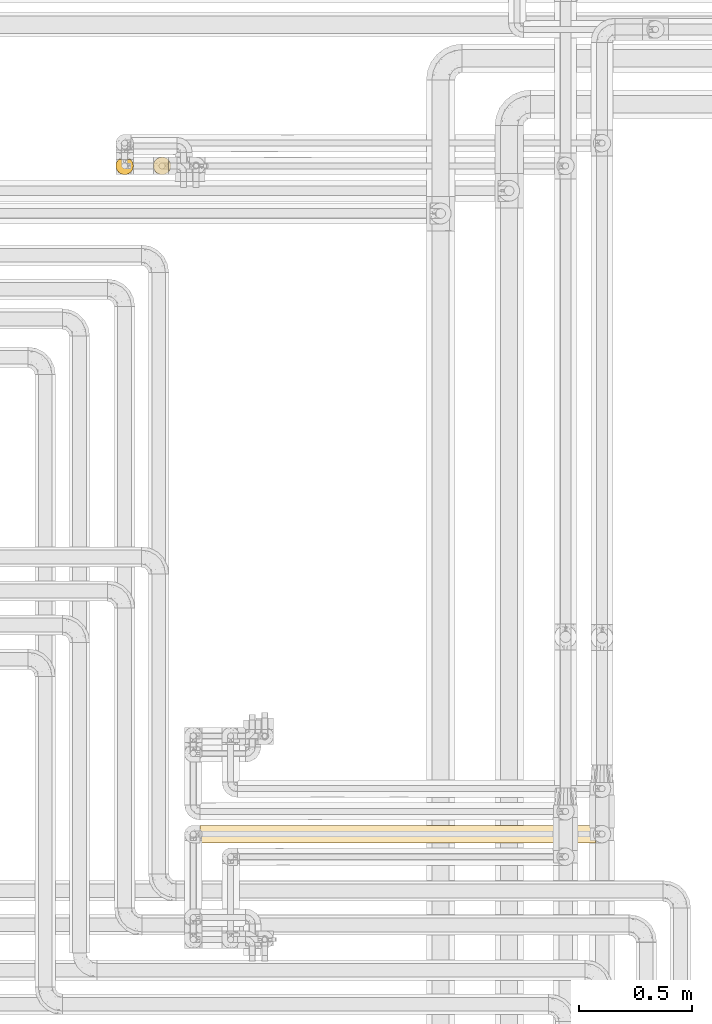
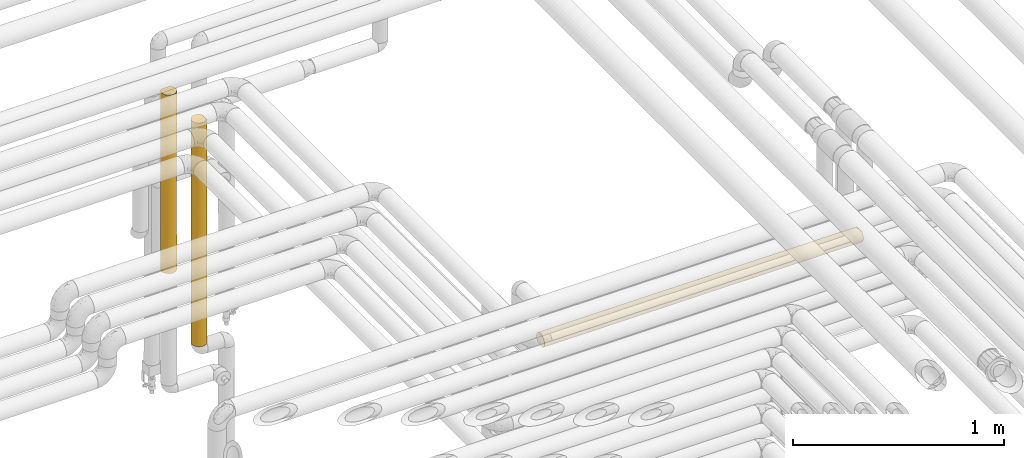
# One storey, part 41 of 827: 3 coverings.
"""IFC2X3 building model written with IfcOpenShell, lengths in millimetres."""

from ifc_helpers import new_model, entity, si_unit, converted_unit, derived_unit, direction, frame, origin, place, context, subcontext, project, spatial, faceted_brep, element, save


model = new_model("IFC2X3")

# Units and contexts
model_context = context("Model", 3, precision=0.01, world=origin(), true_north=direction((6.12303176911189e-17, 1.0)))
body_context = subcontext(model_context, "Body", "Model", "MODEL_VIEW")
ifc_project = project(units=[si_unit("LENGTHUNIT", "METRE", prefix="MILLI"), si_unit("AREAUNIT", "SQUARE_METRE"), si_unit("VOLUMEUNIT", "CUBIC_METRE"), converted_unit("PLANEANGLEUNIT", "DEGREE", entity("IfcRatioMeasure", 0.0174532925199433), si_unit("PLANEANGLEUNIT", "RADIAN"), dimensions=[0, 0, 0, 0, 0, 0, 0]), si_unit("MASSUNIT", "GRAM", prefix="KILO"), derived_unit("MASSDENSITYUNIT", [(si_unit("MASSUNIT", "GRAM", prefix="KILO"), 1), (si_unit("LENGTHUNIT", "METRE"), -3)]), derived_unit("MOMENTOFINERTIAUNIT", [(si_unit("LENGTHUNIT", "METRE"), 4)]), si_unit("TIMEUNIT", "SECOND"), si_unit("FREQUENCYUNIT", "HERTZ"), si_unit("THERMODYNAMICTEMPERATUREUNIT", "DEGREE_CELSIUS"), derived_unit("THERMALTRANSMITTANCEUNIT", [(si_unit("MASSUNIT", "GRAM", prefix="KILO"), 1), (si_unit("THERMODYNAMICTEMPERATUREUNIT", "KELVIN"), -1), (si_unit("TIMEUNIT", "SECOND"), -3)]), derived_unit("VOLUMETRICFLOWRATEUNIT", [(si_unit("LENGTHUNIT", "METRE"), 3), (si_unit("TIMEUNIT", "SECOND"), -1)]), derived_unit("MASSFLOWRATEUNIT", [(si_unit("MASSUNIT", "GRAM", prefix="KILO"), 1), (si_unit("TIMEUNIT", "SECOND"), -1)]), derived_unit("ROTATIONALFREQUENCYUNIT", [(si_unit("TIMEUNIT", "SECOND"), -1)]), si_unit("ELECTRICCURRENTUNIT", "AMPERE"), si_unit("ELECTRICVOLTAGEUNIT", "VOLT"), si_unit("POWERUNIT", "WATT"), si_unit("FORCEUNIT", "NEWTON", prefix="KILO"), si_unit("ILLUMINANCEUNIT", "LUX"), si_unit("LUMINOUSFLUXUNIT", "LUMEN"), si_unit("LUMINOUSINTENSITYUNIT", "CANDELA"), derived_unit("USERDEFINED", [(si_unit("MASSUNIT", "GRAM", prefix="KILO"), -1), (si_unit("LENGTHUNIT", "METRE"), -2), (si_unit("TIMEUNIT", "SECOND"), 3), (si_unit("LUMINOUSFLUXUNIT", "LUMEN"), 1)]), derived_unit("LINEARVELOCITYUNIT", [(si_unit("LENGTHUNIT", "METRE"), 1), (si_unit("TIMEUNIT", "SECOND"), -1)]), si_unit("PRESSUREUNIT", "PASCAL"), derived_unit("USERDEFINED", [(si_unit("LENGTHUNIT", "METRE"), -2), (si_unit("MASSUNIT", "GRAM", prefix="KILO"), 1), (si_unit("TIMEUNIT", "SECOND"), -2)]), derived_unit("LINEARFORCEUNIT", [(si_unit("MASSUNIT", "GRAM", prefix="KILO"), 1), (si_unit("LENGTHUNIT", "METRE"), 1), (si_unit("TIMEUNIT", "SECOND"), -2), (si_unit("LENGTHUNIT", "METRE"), -1)]), derived_unit("PLANARFORCEUNIT", [(si_unit("MASSUNIT", "GRAM", prefix="KILO"), 1), (si_unit("LENGTHUNIT", "METRE"), 1), (si_unit("TIMEUNIT", "SECOND"), -2), (si_unit("LENGTHUNIT", "METRE"), -2)])], contexts=[model_context])

# Site, building, storey
site_placement = place(None, origin())
site = spatial("IfcSite", under=ifc_project, at=site_placement, CompositionType="ELEMENT")
building_placement = place(site_placement, origin())
building = spatial("IfcBuilding", under=site, at=building_placement, CompositionType="ELEMENT")
storey_placement = place(building_placement, frame((0.0, 0.0, 28200.0)))
storey = spatial("IfcBuildingStorey", under=building, at=storey_placement, Name="08", CompositionType="ELEMENT", Elevation=28200.0)

# Coverings
covering_1_placement = place(storey_placement, frame((34650.43, 18294.92, 1257.5)))
element("IfcCovering", 1, at=covering_1_placement, inside=storey, Name=":ADSK_", ObjectType=":ADSK_", PredefinedType="INSULATION", context=body_context, shape_type="Brep", body=[
    faceted_brep([(6.74, 20.8, 1.6), (2.9, 30.06, 1.6), (1.6, 40.0, 1.6), (2.9, 49.93, 1.6), (6.74, 59.2, 1.6), (12.84, 67.15, 1.6), (20.8, 73.25, 1.6), (30.06, 77.09, 1.6), (40.0, 78.4, 1.6), (48.2, 77.51, 1.6), (56.01, 74.9, 1.6), (63.08, 70.68, 1.6), (69.1, 65.05, 1.6), (69.1, 14.94, 1.6), (63.08, 9.31, 1.6), (56.01, 5.09, 1.6), (48.2, 2.48, 1.6), (40.0, 1.6, 1.6), (30.06, 2.9, 1.6), (20.8, 6.74, 1.6), (12.84, 12.84, 1.6), (48.16, 2.47, 1293.5), (55.94, 5.06, 1293.5), (62.99, 9.24, 1293.5), (69.0, 14.82, 1293.5), (69.0, 65.17, 1293.5), (62.99, 70.75, 1293.5), (55.94, 74.93, 1293.5), (48.16, 77.52, 1293.5), (40.0, 78.4, 1293.5), (30.06, 77.09, 1293.5), (20.8, 73.25, 1293.5), (12.84, 67.15, 1293.5), (6.74, 59.2, 1293.5), (2.9, 49.93, 1293.5), (1.6, 40.0, 1293.5), (2.9, 30.06, 1293.5), (6.74, 20.8, 1293.5), (12.84, 12.84, 1293.5), (20.8, 6.74, 1293.5), (30.06, 2.9, 1293.5), (40.0, 1.6, 1293.5), (77.78, 33.17, 1284.71), (75.97, 26.56, 1286.52), (77.48, 31.68, 972.05), (59.58, 6.96, 1107.11), (66.14, 11.87, 1038.3), (52.17, 3.58, 277.97), (40.0, 1.6, 217.97), (66.24, 11.96, 277.98), (59.66, 7.01, 216.52), (73.01, 20.38, 1289.48), (74.55, 23.24, 942.55), (70.47, 16.64, 908.31), (78.4, 40.0, 1067.72), (78.4, 40.0, 876.39), (52.12, 3.56, 1038.32), (59.58, 6.96, 886.32), (76.54, 28.2, 648.87), (74.59, 23.33, 353.75), (77.52, 31.84, 335.45), (78.4, 40.0, 227.27), (78.4, 40.0, 443.64), (71.31, 17.78, 216.97), (73.07, 20.48, 5.57), (66.0, 11.74, 786.74), (65.83, 11.58, 548.84), (70.86, 17.15, 647.83), (76.0, 26.63, 8.5), (77.79, 33.21, 10.29), (71.01, 17.35, 432.2), (40.0, 1.6, 428.0), (52.92, 3.84, 494.01), (60.93, 7.8, 674.6), (59.66, 7.01, 462.3), (50.4, 3.03, 697.42), (40.0, 1.6, 1077.12), (78.4, 40.0, 1284.1), (78.4, 40.0, 10.9), (78.4, 40.0, 660.01), (40.0, 1.6, 860.75), (40.0, 1.6, 650.71), (40.0, 1.6, 644.38), (40.0, 1.6, 434.34), (40.0, 1.6, 867.09), (16.62, 9.53, 1034.3), (9.53, 16.62, 969.22), (32.88, 2.26, 326.15), (31.56, 2.53, 650.71), (25.3, 4.52, 373.29), (25.3, 4.52, 921.8), (32.84, 2.27, 972.1), (1.6, 40.0, 1077.12), (1.6, 40.0, 217.97), (23.7, 5.22, 684.79), (1.6, 40.0, 428.0), (2.27, 32.83, 322.99), (4.52, 25.3, 1048.44), (6.84, 20.62, 572.76), (11.32, 14.46, 577.99), (7.88, 18.94, 777.8), (2.29, 32.71, 968.94), (4.52, 25.3, 763.78), (9.53, 16.62, 373.29), (4.52, 25.3, 272.12), (16.62, 9.53, 272.12), (16.62, 9.53, 647.55), (3.48, 28.11, 517.95), (2.22, 33.12, 731.85), (12.38, 13.31, 791.26), (17.3, 9.02, 840.92), (1.6, 40.0, 867.09), (1.6, 40.0, 860.75), (1.6, 40.0, 644.38), (1.6, 40.0, 434.34), (1.6, 40.0, 650.71), (9.53, 63.37, 1034.3), (16.62, 70.46, 969.22), (2.26, 47.12, 326.15), (2.53, 48.43, 650.71), (4.52, 54.69, 373.29), (4.52, 54.69, 921.8), (2.27, 47.15, 972.1), (40.0, 78.4, 1077.12), (40.0, 78.4, 217.97), (40.0, 78.4, 214.8), (5.22, 56.29, 684.79), (40.0, 78.4, 428.0), (32.83, 77.72, 322.99), (25.3, 75.47, 1048.44), (20.62, 73.15, 572.76), (14.46, 68.67, 577.99), (18.94, 72.11, 777.8), (32.71, 77.7, 968.94), (25.3, 75.47, 763.78), (16.62, 70.46, 373.29), (25.3, 75.47, 272.12), (9.53, 63.37, 272.12), (9.53, 63.37, 647.55), (28.11, 76.51, 517.95), (33.12, 77.77, 731.85), (13.31, 67.61, 791.26), (9.02, 62.69, 840.92), (40.0, 78.4, 860.75), (40.0, 78.4, 644.37), (52.12, 76.43, 1015.67), (74.55, 56.75, 943.52), (70.97, 62.69, 863.0), (71.23, 62.33, 1078.4), (59.58, 73.03, 828.13), (59.58, 73.03, 1078.96), (65.9, 68.35, 749.13), (66.06, 68.19, 508.81), (60.97, 72.16, 617.52), (73.01, 59.61, 1289.48), (59.66, 72.98, 186.49), (66.24, 68.03, 256.35), (66.14, 68.12, 1015.66), (76.0, 53.36, 8.5), (73.07, 59.51, 5.57), (74.59, 56.66, 352.23), (52.17, 76.41, 256.35), (75.97, 53.43, 1286.52), (77.78, 46.82, 1284.71), (77.48, 48.31, 972.05), (59.66, 72.98, 406.31), (50.42, 76.95, 603.65), (70.53, 63.27, 387.8), (47.86, 77.58, 822.29), (70.94, 62.73, 647.24), (77.79, 46.78, 10.29), (77.52, 48.15, 335.45), (76.52, 51.85, 648.58)], [[[0, 1, 2, 3, 4, 5, 6, 7, 8, 9, 10, 11, 12, 13, 14, 15, 16, 17, 18, 19, 20]], [[21, 22, 23, 24, 25, 26, 27, 28, 29, 30, 31, 32, 33, 34, 35, 36, 37, 38, 39, 40, 41]], [[42, 43, 44]], [[45, 46, 23]], [[46, 24, 23]], [[47, 48, 16]], [[14, 49, 50]], [[43, 51, 52]], [[53, 24, 46]], [[54, 44, 55]], [[45, 56, 57]], [[58, 59, 60]], [[61, 62, 60]], [[63, 64, 59]], [[65, 66, 67]], [[15, 47, 16]], [[68, 59, 64]], [[46, 65, 53]], [[61, 60, 69]], [[59, 70, 63]], [[71, 47, 72]], [[66, 65, 73]], [[63, 13, 64]], [[50, 15, 14]], [[74, 47, 50]], [[45, 23, 22]], [[56, 75, 57]], [[21, 76, 56]], [[54, 77, 42]], [[58, 67, 59]], [[49, 14, 13]], [[52, 67, 58]], [[22, 21, 56]], [[72, 47, 74]], [[16, 48, 17]], [[68, 69, 60]], [[69, 78, 61]], [[58, 60, 62]], [[60, 59, 68]], [[79, 55, 58, 62]], [[55, 44, 58]], [[75, 80, 81, 82, 83, 71]], [[75, 56, 80]], [[75, 72, 73]], [[65, 46, 57]], [[53, 51, 24]], [[44, 43, 52]], [[42, 44, 54]], [[58, 44, 52]], [[56, 45, 22]], [[71, 48, 47]], [[46, 45, 57]], [[73, 65, 57]], [[53, 67, 52]], [[74, 49, 66]], [[70, 49, 63]], [[67, 53, 65]], [[51, 53, 52]], [[75, 73, 57]], [[66, 73, 74]], [[74, 50, 49]], [[15, 50, 47]], [[70, 59, 67]], [[13, 63, 49]], [[67, 66, 70]], [[49, 70, 66]], [[76, 21, 41]], [[56, 76, 84, 80]], [[73, 72, 74]], [[71, 72, 75]], [[85, 38, 86]], [[87, 88, 89]], [[18, 48, 87]], [[18, 89, 19]], [[40, 39, 90]], [[91, 40, 90]], [[36, 35, 92]], [[1, 93, 2]], [[83, 88, 87]], [[89, 88, 94]], [[95, 93, 96]], [[37, 97, 86]], [[98, 99, 100]], [[97, 101, 102]], [[40, 76, 41]], [[18, 17, 48]], [[87, 48, 71, 83]], [[103, 104, 0]], [[105, 20, 19]], [[37, 36, 97]], [[37, 86, 38]], [[89, 105, 19]], [[103, 0, 20]], [[1, 0, 104]], [[105, 106, 99]], [[102, 107, 98]], [[108, 107, 102]], [[38, 85, 39]], [[102, 101, 108]], [[109, 110, 85]], [[98, 107, 104]], [[106, 105, 89]], [[103, 20, 105]], [[85, 86, 109]], [[90, 39, 85]], [[92, 101, 36]], [[97, 102, 100]], [[101, 92, 111, 112]], [[101, 112, 108]], [[36, 101, 97]], [[107, 113, 114, 95]], [[96, 107, 95]], [[108, 113, 107]], [[98, 104, 103]], [[103, 99, 98]], [[109, 100, 99]], [[108, 112, 115, 113]], [[105, 99, 103]], [[109, 99, 106]], [[109, 106, 110]], [[109, 86, 100]], [[97, 100, 86]], [[98, 100, 102]], [[88, 83, 82, 81, 80, 84]], [[18, 87, 89]], [[91, 88, 84]], [[88, 90, 94]], [[40, 91, 76]], [[84, 76, 91]], [[88, 91, 90]], [[96, 1, 104]], [[1, 96, 93]], [[107, 96, 104]], [[94, 110, 106]], [[90, 85, 110]], [[110, 94, 90]], [[89, 94, 106]], [[116, 32, 117]], [[118, 119, 120]], [[3, 93, 118]], [[3, 120, 4]], [[34, 33, 121]], [[122, 34, 121]], [[30, 29, 123]], [[7, 124, 125, 8]], [[114, 119, 118]], [[120, 119, 126]], [[127, 124, 128]], [[31, 129, 117]], [[130, 131, 132]], [[129, 133, 134]], [[34, 92, 35]], [[3, 2, 93]], [[118, 93, 95, 114]], [[135, 136, 6]], [[137, 5, 4]], [[31, 30, 129]], [[31, 117, 32]], [[120, 137, 4]], [[135, 6, 5]], [[7, 6, 136]], [[137, 138, 131]], [[134, 139, 130]], [[140, 139, 134]], [[32, 116, 33]], [[134, 133, 140]], [[141, 142, 116]], [[130, 139, 136]], [[138, 137, 120]], [[135, 5, 137]], [[116, 117, 141]], [[121, 33, 116]], [[123, 133, 30]], [[129, 134, 132]], [[133, 123, 143]], [[133, 143, 140]], [[30, 133, 129]], [[139, 144, 127]], [[128, 139, 127]], [[140, 144, 139]], [[130, 136, 135]], [[135, 131, 130]], [[141, 132, 131]], [[140, 143, 144]], [[137, 131, 135]], [[141, 131, 138]], [[141, 138, 142]], [[141, 117, 132]], [[129, 132, 117]], [[130, 132, 134]], [[119, 114, 113, 115, 112, 111]], [[3, 118, 120]], [[122, 119, 111]], [[119, 121, 126]], [[34, 122, 92]], [[111, 92, 122]], [[119, 122, 121]], [[128, 7, 136]], [[7, 128, 124]], [[139, 128, 136]], [[126, 142, 138]], [[121, 116, 142]], [[142, 126, 121]], [[120, 126, 138]], [[145, 123, 28]], [[146, 147, 148]], [[149, 145, 150]], [[151, 152, 153]], [[148, 25, 154]], [[11, 155, 156]], [[26, 157, 150]], [[123, 29, 28]], [[158, 159, 160]], [[9, 125, 161]], [[162, 163, 164]], [[27, 145, 28]], [[165, 161, 166]], [[11, 10, 155]], [[156, 152, 167]], [[168, 149, 166]], [[151, 169, 152]], [[150, 27, 26]], [[170, 171, 61]], [[25, 157, 26]], [[171, 160, 172]], [[164, 163, 54]], [[143, 123, 168, 144]], [[165, 155, 161]], [[54, 55, 164]], [[170, 158, 171]], [[167, 12, 156]], [[146, 148, 154]], [[11, 156, 12]], [[172, 169, 146]], [[61, 78, 170]], [[146, 154, 162]], [[10, 9, 161]], [[172, 55, 79, 62]], [[171, 158, 160]], [[62, 61, 171]], [[160, 169, 172]], [[163, 77, 54]], [[172, 62, 171]], [[149, 168, 145]], [[166, 161, 127]], [[166, 127, 144]], [[153, 166, 149]], [[152, 156, 165]], [[167, 159, 12]], [[164, 172, 146]], [[125, 9, 8]], [[164, 146, 162]], [[161, 155, 10]], [[156, 155, 165]], [[153, 152, 165]], [[167, 169, 160]], [[149, 157, 151]], [[147, 157, 148]], [[169, 167, 152]], [[159, 167, 160]], [[166, 153, 165]], [[151, 153, 149]], [[149, 150, 157]], [[27, 150, 145]], [[147, 146, 169]], [[25, 148, 157]], [[169, 151, 147]], [[157, 147, 151]], [[168, 123, 145]], [[55, 172, 164]], [[161, 125, 124, 127]], [[144, 168, 166]], [[12, 159, 158, 170, 78, 69, 68, 64, 13]], [[24, 51, 43, 42, 77, 163, 162, 154, 25]]]),
])
covering_2_placement = place(storey_placement, frame((34855.35, 15349.6, 2960.0)))
element("IfcCovering", 2, at=covering_2_placement, inside=storey, Name=":ADSK_", ObjectType=":ADSK_", PredefinedType="INSULATION", context=body_context, shape_type="Brep", body=[
    faceted_brep([(1745.19, 59.2, 6.74), (1745.19, 67.15, 12.84), (1745.19, 73.25, 20.8), (1745.19, 77.09, 30.06), (1745.19, 78.4, 40.0), (1745.19, 77.51, 48.2), (1745.19, 74.9, 56.01), (1745.19, 70.68, 63.08), (1745.19, 65.05, 69.1), (1745.19, 14.94, 69.1), (1745.19, 9.31, 63.08), (1745.19, 5.09, 56.01), (1745.19, 2.48, 48.2), (1745.19, 1.6, 40.0), (1745.19, 2.9, 30.06), (1745.19, 6.74, 20.8), (1745.19, 12.84, 12.84), (1745.19, 20.8, 6.74), (1745.19, 30.06, 2.9), (1745.19, 40.0, 1.6), (1745.19, 49.93, 2.9), (1.6, 77.09, 49.93), (1.6, 78.4, 40.0), (1.6, 77.51, 31.79), (1.6, 74.9, 23.98), (1.6, 70.68, 16.91), (1.6, 65.05, 10.9), (1.6, 14.94, 10.9), (1.6, 9.31, 16.91), (1.6, 5.09, 23.98), (1.6, 2.48, 31.79), (1.6, 1.6, 40.0), (1.6, 2.9, 49.93), (1.6, 6.74, 59.2), (1.6, 12.84, 67.15), (1.6, 20.8, 73.25), (1.6, 30.06, 77.09), (1.6, 40.0, 78.4), (1.6, 49.93, 77.09), (1.6, 59.2, 73.25), (1.6, 67.15, 67.15), (1.6, 73.25, 59.2), (218.66, 7.01, 20.33), (287.24, 11.96, 13.75), (544.14, 12.26, 13.43), (717.19, 17.22, 9.08), (783.66, 11.23, 14.56), (287.23, 3.58, 27.82), (217.97, 1.6, 40.0), (616.82, 2.85, 30.25), (434.34, 1.6, 40.0), (485.18, 7.01, 20.33), (335.45, 31.75, 2.49), (688.07, 29.53, 3.05), (384.99, 23.31, 5.41), (406.86, 16.78, 9.41), (194.06, 17.51, 8.86), (1248.41, 14.02, 11.72), (1485.61, 16.62, 9.53), (1419.01, 9.53, 16.62), (1528.82, 1.6, 40.0), (1497.5, 4.52, 25.3), (1417.48, 2.29, 32.74), (1210.56, 4.52, 25.3), (806.62, 6.2, 21.76), (967.81, 3.45, 28.2), (227.27, 40.0, 1.6), (10.29, 33.21, 2.2), (1183.1, 33.11, 2.22), (1310.79, 40.0, 1.6), (1419.81, 32.72, 2.29), (1528.82, 40.0, 1.6), (8.5, 26.63, 4.0), (956.23, 28.08, 3.49), (794.35, 23.31, 5.41), (1499.45, 25.3, 4.52), (5.57, 20.48, 6.92), (443.64, 40.0, 1.6), (1220.82, 7.97, 18.8), (1027.44, 6.38, 21.43), (1181.82, 2.22, 33.08), (10.9, 40.0, 1.6), (660.01, 40.0, 1.6), (876.39, 40.0, 1.6), (1026.75, 10.9, 14.94), (1003.5, 19.04, 7.82), (589.67, 22.07, 6.04), (867.09, 1.6, 40.0), (660.17, 1.6, 40.0), (650.71, 1.6, 40.0), (440.64, 1.6, 40.0), (1304.51, 19.53, 7.5), (1312.45, 1.6, 40.0), (1306.14, 1.6, 40.0), (1086.61, 1.6, 40.0), (879.7, 1.6, 40.0), (1096.08, 1.6, 40.0), (1214.19, 25.3, 4.52), (1093.59, 40.0, 1.6), (335.45, 48.24, 2.49), (688.07, 50.46, 3.05), (406.86, 63.21, 9.41), (194.06, 62.48, 8.86), (287.24, 68.03, 13.75), (287.23, 76.41, 27.82), (218.66, 72.98, 20.33), (544.14, 67.73, 13.43), (10.29, 46.78, 2.2), (8.5, 53.36, 4.0), (485.18, 72.98, 20.33), (1181.82, 77.77, 33.08), (1306.14, 78.4, 40.0), (1417.48, 77.7, 32.74), (1312.45, 78.4, 40.0), (1528.82, 78.4, 40.0), (1499.45, 54.69, 4.52), (1419.81, 47.27, 2.29), (1214.19, 54.69, 4.52), (384.99, 56.68, 5.41), (1183.1, 46.89, 2.22), (956.23, 51.91, 3.49), (806.62, 73.79, 21.76), (967.81, 76.54, 28.2), (1027.44, 73.61, 21.43), (1497.5, 75.47, 25.3), (5.57, 59.51, 6.92), (1419.01, 70.46, 16.62), (1485.61, 63.37, 9.53), (1220.82, 72.02, 18.8), (616.82, 77.14, 30.25), (1210.56, 75.47, 25.3), (434.34, 78.4, 40.0), (217.97, 78.4, 40.0), (1003.5, 60.95, 7.82), (717.19, 62.77, 9.08), (794.35, 56.68, 5.41), (589.67, 57.93, 6.04), (1248.41, 65.97, 11.72), (1026.75, 69.09, 14.94), (783.66, 68.76, 14.56), (440.65, 78.4, 40.0), (650.71, 78.4, 40.0), (660.17, 78.4, 40.0), (867.09, 78.4, 40.0), (1304.51, 60.46, 7.5), (1086.61, 78.4, 40.0), (879.7, 78.4, 40.0), (1096.07, 78.4, 40.0), (249.29, 75.47, 54.69), (327.78, 70.46, 63.37), (525.97, 72.02, 61.19), (1411.33, 48.24, 77.5), (1738.29, 53.36, 76.0), (1361.8, 56.68, 74.58), (247.34, 54.69, 75.47), (532.6, 54.69, 75.47), (563.69, 46.89, 77.77), (790.56, 51.91, 76.5), (536.23, 75.47, 54.69), (719.35, 73.61, 58.56), (261.18, 63.37, 70.46), (329.31, 77.7, 47.25), (564.97, 77.77, 46.91), (1459.55, 76.41, 52.17), (940.16, 73.79, 58.23), (778.98, 76.54, 51.79), (1058.72, 50.46, 76.94), (1303.14, 40.0, 78.4), (1202.65, 67.73, 66.56), (1459.55, 68.03, 66.24), (1261.61, 72.98, 59.66), (1528.13, 72.98, 59.66), (1519.52, 40.0, 78.4), (1086.77, 40.0, 78.4), (870.4, 40.0, 78.4), (1736.5, 46.78, 77.79), (1129.97, 77.14, 49.74), (1339.93, 63.21, 70.58), (1552.73, 62.48, 71.13), (1741.22, 59.51, 73.07), (217.97, 40.0, 78.4), (326.98, 47.27, 77.7), (1735.89, 40.0, 78.4), (743.28, 60.95, 72.17), (1029.6, 62.77, 70.91), (952.44, 56.68, 74.58), (1157.12, 57.93, 73.95), (498.37, 65.97, 68.27), (720.04, 69.09, 65.05), (963.13, 68.76, 65.43), (442.27, 60.46, 72.49), (436.0, 40.0, 78.4), (653.2, 40.0, 78.4), (247.34, 25.3, 75.47), (1339.93, 16.78, 70.58), (1029.6, 17.22, 70.91), (1202.65, 12.26, 66.56), (563.69, 33.11, 77.77), (326.98, 32.72, 77.7), (790.56, 28.08, 76.5), (952.44, 23.31, 74.58), (1058.72, 29.53, 76.94), (1552.73, 17.51, 71.13), (1741.22, 20.48, 73.07), (327.78, 9.53, 63.37), (249.29, 4.52, 54.69), (1738.29, 26.63, 76.0), (1361.8, 23.31, 74.58), (1528.13, 7.01, 59.66), (1411.33, 31.75, 77.5), (1736.5, 33.21, 77.79), (1459.55, 11.96, 66.24), (1459.55, 3.58, 52.17), (329.31, 2.29, 47.25), (536.23, 4.52, 54.69), (498.37, 14.02, 68.27), (261.18, 16.62, 70.46), (1261.61, 7.01, 59.66), (963.13, 11.23, 65.43), (1129.97, 2.85, 49.74), (940.16, 6.2, 58.23), (778.98, 3.45, 51.79), (719.35, 6.38, 58.56), (525.97, 7.97, 61.19), (564.97, 2.22, 46.91), (720.04, 10.9, 65.05), (743.28, 19.04, 72.17), (1157.12, 22.07, 73.95), (442.27, 19.53, 72.49), (532.6, 25.3, 75.47)], [[[0, 1, 2, 3, 4, 5, 6, 7, 8, 9, 10, 11, 12, 13, 14, 15, 16, 17, 18, 19, 20]], [[21, 22, 23, 24, 25, 26, 27, 28, 29, 30, 31, 32, 33, 34, 35, 36, 37, 38, 39, 40, 41]], [[42, 29, 28]], [[43, 42, 28]], [[44, 45, 46]], [[47, 48, 30]], [[47, 49, 50]], [[47, 42, 51]], [[52, 53, 54]], [[54, 55, 56]], [[57, 58, 59]], [[14, 13, 60]], [[61, 62, 63]], [[49, 64, 65]], [[27, 43, 28]], [[29, 47, 30]], [[66, 52, 67]], [[14, 61, 15]], [[68, 69, 70]], [[69, 71, 70]], [[43, 44, 51]], [[56, 72, 54]], [[61, 59, 15]], [[73, 74, 53]], [[16, 15, 59]], [[75, 18, 17]], [[58, 16, 59]], [[56, 27, 76]], [[66, 77, 52]], [[55, 45, 44]], [[72, 67, 52]], [[49, 47, 51]], [[59, 78, 57]], [[63, 79, 78]], [[63, 62, 80]], [[16, 58, 17]], [[67, 81, 66]], [[18, 71, 19]], [[53, 77, 82, 83]], [[52, 54, 72]], [[84, 85, 57]], [[53, 74, 86]], [[63, 80, 65]], [[45, 74, 85]], [[49, 51, 64]], [[49, 87, 88, 89, 90, 50]], [[48, 47, 50]], [[48, 31, 30]], [[58, 91, 75]], [[60, 62, 14]], [[61, 63, 78]], [[58, 75, 17]], [[70, 18, 75]], [[51, 44, 46]], [[65, 79, 63]], [[62, 60, 92, 93]], [[62, 93, 80]], [[14, 62, 61]], [[65, 94, 95, 87]], [[65, 64, 79]], [[65, 80, 94]], [[49, 65, 87]], [[80, 93, 96, 94]], [[97, 68, 70]], [[18, 70, 71]], [[97, 70, 75]], [[73, 68, 97]], [[73, 98, 68]], [[73, 97, 85]], [[83, 73, 53]], [[57, 91, 58]], [[46, 85, 84]], [[98, 73, 83]], [[98, 69, 68]], [[91, 85, 97]], [[64, 84, 79]], [[78, 59, 61]], [[79, 84, 78]], [[57, 78, 84]], [[55, 44, 43]], [[85, 46, 45]], [[84, 64, 46]], [[51, 46, 64]], [[43, 27, 56]], [[55, 54, 86]], [[56, 76, 72]], [[43, 56, 55]], [[85, 91, 57]], [[75, 91, 97]], [[85, 74, 73]], [[86, 74, 45]], [[55, 86, 45]], [[53, 86, 54]], [[51, 42, 43]], [[29, 42, 47]], [[77, 53, 52]], [[77, 99, 100]], [[101, 102, 103]], [[104, 105, 24]], [[101, 103, 106]], [[105, 103, 25]], [[26, 25, 103]], [[107, 108, 99]], [[77, 66, 99]], [[106, 103, 109]], [[110, 111, 112]], [[20, 19, 71]], [[112, 111, 113, 114]], [[115, 116, 117]], [[99, 108, 118]], [[115, 0, 20]], [[117, 119, 120]], [[121, 122, 123]], [[82, 77, 100, 83]], [[66, 81, 107]], [[3, 2, 124]], [[104, 24, 23]], [[125, 102, 108]], [[126, 2, 1]], [[127, 126, 1]], [[124, 126, 128]], [[109, 104, 129]], [[121, 109, 129]], [[103, 105, 109]], [[130, 128, 123]], [[131, 104, 132]], [[102, 125, 26]], [[104, 23, 132]], [[129, 104, 131]], [[127, 1, 0]], [[3, 114, 4]], [[117, 120, 133]], [[107, 99, 66]], [[117, 116, 119]], [[99, 118, 100]], [[134, 135, 136]], [[133, 120, 135]], [[126, 127, 137]], [[138, 133, 139]], [[129, 131, 140, 141, 142, 143]], [[110, 130, 122]], [[23, 22, 132]], [[115, 127, 0]], [[133, 137, 144]], [[126, 124, 2]], [[112, 3, 124]], [[71, 116, 20]], [[115, 117, 144]], [[129, 143, 122]], [[139, 134, 106]], [[130, 110, 112]], [[3, 112, 114]], [[130, 112, 124]], [[130, 123, 122]], [[122, 145, 110]], [[129, 122, 121]], [[116, 71, 69]], [[122, 143, 146, 145]], [[110, 145, 147, 111]], [[116, 69, 119]], [[20, 116, 115]], [[120, 98, 83]], [[120, 83, 100]], [[119, 98, 120]], [[135, 120, 100]], [[139, 133, 134]], [[138, 128, 137]], [[119, 69, 98]], [[144, 137, 127]], [[133, 138, 137]], [[130, 124, 128]], [[138, 121, 123]], [[137, 128, 126]], [[138, 123, 128]], [[139, 109, 121]], [[134, 136, 101]], [[109, 139, 106]], [[121, 138, 139]], [[134, 101, 106]], [[118, 108, 102]], [[103, 102, 26]], [[118, 102, 101]], [[115, 144, 127]], [[133, 144, 117]], [[136, 100, 118]], [[133, 135, 134]], [[100, 136, 135]], [[101, 136, 118]], [[24, 105, 25]], [[109, 105, 104]], [[148, 149, 150]], [[151, 152, 153]], [[154, 39, 38]], [[155, 156, 157]], [[158, 150, 159]], [[40, 160, 149]], [[161, 140, 131, 132]], [[162, 140, 161]], [[113, 163, 114]], [[159, 164, 165]], [[151, 166, 167]], [[168, 169, 170]], [[169, 171, 170]], [[167, 172, 151]], [[163, 171, 6]], [[173, 167, 166, 174]], [[149, 41, 40]], [[175, 152, 151]], [[164, 170, 176]], [[177, 178, 169]], [[177, 169, 168]], [[7, 171, 169]], [[41, 148, 21]], [[7, 169, 8]], [[152, 179, 178]], [[38, 37, 180]], [[170, 163, 176]], [[154, 181, 155]], [[172, 182, 175]], [[163, 6, 5]], [[178, 179, 8]], [[163, 5, 114]], [[176, 163, 113]], [[160, 40, 39]], [[21, 132, 22]], [[155, 157, 183]], [[175, 151, 172]], [[155, 181, 156]], [[151, 153, 166]], [[184, 185, 186]], [[183, 157, 185]], [[149, 160, 187]], [[188, 183, 189]], [[176, 113, 111, 147, 145, 146]], [[162, 158, 165]], [[5, 4, 114]], [[154, 160, 39]], [[183, 187, 190]], [[149, 148, 41]], [[161, 21, 148]], [[180, 181, 38]], [[154, 155, 190]], [[176, 146, 165]], [[189, 184, 168]], [[158, 162, 161]], [[21, 161, 132]], [[158, 161, 148]], [[158, 159, 165]], [[165, 142, 162]], [[176, 165, 164]], [[181, 180, 191]], [[165, 146, 143, 142]], [[162, 142, 141, 140]], [[181, 191, 156]], [[38, 181, 154]], [[157, 192, 174]], [[157, 174, 166]], [[156, 192, 157]], [[185, 157, 166]], [[189, 183, 184]], [[188, 150, 187]], [[156, 191, 192]], [[190, 187, 160]], [[183, 188, 187]], [[158, 148, 150]], [[188, 164, 159]], [[187, 150, 149]], [[188, 159, 150]], [[189, 170, 164]], [[184, 186, 177]], [[170, 189, 168]], [[164, 188, 189]], [[184, 177, 168]], [[153, 152, 178]], [[169, 178, 8]], [[153, 178, 177]], [[154, 190, 160]], [[183, 190, 155]], [[186, 166, 153]], [[183, 185, 184]], [[166, 186, 185]], [[177, 186, 153]], [[6, 171, 7]], [[170, 171, 163]], [[35, 193, 36]], [[194, 195, 196]], [[197, 191, 198]], [[199, 200, 201]], [[202, 9, 203]], [[34, 33, 204]], [[33, 32, 205]], [[206, 207, 202]], [[208, 11, 10]], [[172, 209, 210]], [[194, 202, 207]], [[9, 211, 10]], [[167, 209, 172]], [[212, 60, 12]], [[205, 213, 214]], [[32, 31, 48]], [[215, 216, 204]], [[206, 210, 209]], [[208, 10, 211]], [[211, 196, 217]], [[208, 217, 212]], [[11, 212, 12]], [[196, 195, 218]], [[191, 180, 198]], [[212, 219, 92]], [[219, 220, 221]], [[204, 33, 205]], [[216, 34, 204]], [[209, 201, 207]], [[219, 212, 217]], [[12, 60, 13]], [[214, 222, 223]], [[214, 213, 224]], [[34, 216, 35]], [[210, 182, 172]], [[36, 180, 37]], [[201, 167, 173, 174]], [[209, 207, 206]], [[225, 226, 215]], [[201, 200, 227]], [[214, 224, 221]], [[195, 200, 226]], [[219, 217, 220]], [[219, 95, 94, 96, 93, 92]], [[204, 223, 215]], [[92, 60, 212]], [[216, 228, 193]], [[48, 213, 32]], [[205, 214, 223]], [[216, 193, 35]], [[198, 36, 193]], [[217, 196, 218]], [[221, 222, 214]], [[213, 48, 50, 90]], [[213, 90, 224]], [[32, 213, 205]], [[221, 88, 87, 95]], [[221, 220, 222]], [[221, 224, 88]], [[219, 221, 95]], [[224, 90, 89, 88]], [[229, 197, 198]], [[36, 198, 180]], [[229, 198, 193]], [[199, 197, 229]], [[199, 192, 197]], [[199, 229, 226]], [[174, 199, 201]], [[215, 228, 216]], [[218, 226, 225]], [[192, 199, 174]], [[192, 191, 197]], [[228, 226, 229]], [[220, 225, 222]], [[223, 204, 205]], [[222, 225, 223]], [[215, 223, 225]], [[194, 196, 211]], [[226, 218, 195]], [[225, 220, 218]], [[217, 218, 220]], [[211, 9, 202]], [[194, 207, 227]], [[202, 203, 206]], [[211, 202, 194]], [[226, 228, 215]], [[193, 228, 229]], [[226, 200, 199]], [[227, 200, 195]], [[194, 227, 195]], [[201, 227, 207]], [[217, 208, 211]], [[11, 208, 212]], [[167, 201, 209]], [[210, 206, 203, 9, 8, 179, 152, 175, 182]], [[26, 125, 108, 107, 81, 67, 72, 76, 27]]]),
])
covering_3_placement = place(storey_placement, frame((34485.39, 18294.92, 1737.4)))
element("IfcCovering", 3, at=covering_3_placement, inside=storey, Name=":ADSK_", ObjectType=":ADSK_", PredefinedType="INSULATION", context=body_context, shape_type="Brep", body=[
    faceted_brep([(73.25, 20.8, 1033.5), (77.09, 30.06, 1033.5), (78.4, 40.0, 1033.5), (77.51, 48.2, 1033.5), (74.9, 56.01, 1033.5), (70.68, 63.08, 1033.5), (65.05, 69.1, 1033.5), (14.94, 69.1, 1033.5), (9.31, 63.08, 1033.5), (5.09, 56.01, 1033.5), (2.48, 48.2, 1033.5), (1.6, 40.0, 1033.5), (2.9, 30.06, 1033.5), (6.74, 20.8, 1033.5), (12.84, 12.84, 1033.5), (20.8, 6.74, 1033.5), (30.06, 2.9, 1033.5), (40.0, 1.6, 1033.5), (49.93, 2.9, 1033.5), (59.2, 6.74, 1033.5), (67.15, 12.84, 1033.5), (74.93, 55.94, 1.6), (77.52, 48.16, 1.6), (78.4, 40.0, 1.6), (77.09, 30.06, 1.6), (73.25, 20.8, 1.6), (67.15, 12.84, 1.6), (59.2, 6.74, 1.6), (49.93, 2.9, 1.6), (40.0, 1.6, 1.6), (30.06, 2.9, 1.6), (20.8, 6.74, 1.6), (12.84, 12.84, 1.6), (6.74, 20.8, 1.6), (2.9, 30.06, 1.6), (1.6, 40.0, 1.6), (2.47, 48.16, 1.6), (5.06, 55.94, 1.6), (9.24, 62.99, 1.6), (14.82, 69.0, 1.6), (65.17, 69.0, 1.6), (70.75, 62.99, 1.6), (76.41, 52.17, 702.15), (78.4, 40.0, 434.34), (77.02, 50.18, 326.15), (73.03, 59.58, 204.86), (50.28, 76.99, 369.34), (40.0, 78.4, 591.45), (50.2, 77.01, 717.61), (59.61, 73.01, 5.61), (62.62, 71.02, 251.23), (73.03, 59.58, 440.06), (68.63, 65.58, 322.46), (69.13, 65.01, 656.21), (73.16, 59.36, 807.44), (62.66, 70.99, 517.91), (62.51, 71.1, 784.12), (78.4, 40.0, 733.92), (46.78, 77.79, 1024.8), (40.0, 78.4, 807.82), (40.0, 78.4, 1024.2), (78.4, 40.0, 217.97), (53.43, 75.97, 8.57), (55.51, 75.12, 218.77), (46.82, 77.78, 10.38), (53.36, 76.0, 1026.6), (59.51, 73.07, 1029.52), (57.16, 74.34, 647.32), (40.0, 78.4, 301.22), (56.84, 74.5, 434.6), (40.0, 78.4, 11.0), (24.48, 75.12, 218.77), (33.17, 77.78, 10.38), (26.56, 75.97, 8.57), (20.38, 73.01, 5.61), (17.37, 71.02, 251.23), (33.21, 77.79, 1024.8), (29.79, 77.01, 717.61), (26.63, 76.0, 1026.6), (3.58, 52.17, 702.15), (1.6, 40.0, 733.92), (6.55, 58.87, 655.29), (23.15, 74.5, 434.6), (29.71, 76.99, 369.34), (11.36, 65.58, 322.46), (17.33, 70.99, 517.91), (2.5, 48.27, 485.88), (22.83, 74.34, 647.32), (6.96, 59.58, 204.86), (17.48, 71.1, 784.12), (20.48, 73.07, 1029.52), (3.56, 52.12, 268.74), (1.6, 40.0, 217.97), (6.96, 59.58, 440.06), (10.86, 65.01, 656.21), (1.6, 40.0, 817.12), (1.6, 40.0, 301.17), (1.6, 40.0, 434.34), (1.6, 40.0, 600.75), (9.53, 16.62, 239.24), (4.52, 25.3, 320.57), (9.53, 16.62, 795.85), (16.62, 9.53, 742.08), (14.78, 11.04, 531.33), (25.3, 4.52, 593.84), (4.52, 25.3, 714.52), (5.64, 22.84, 517.55), (2.29, 32.75, 450.96), (2.24, 32.96, 708.94), (16.62, 9.53, 320.57), (30.07, 2.9, 789.72), (32.79, 2.28, 326.15), (40.0, 1.6, 434.34), (33.12, 2.22, 563.26), (2.33, 32.54, 220.29), (22.89, 5.61, 802.02), (9.53, 16.62, 517.55), (40.0, 1.6, 217.97), (40.0, 1.6, 301.17), (25.3, 4.52, 259.75), (40.0, 1.6, 600.75), (40.0, 1.6, 733.92), (40.0, 1.6, 817.12), (63.37, 9.53, 239.24), (54.69, 4.52, 320.57), (63.37, 9.53, 795.85), (70.46, 16.62, 742.08), (68.96, 14.78, 531.33), (75.47, 25.3, 593.84), (54.69, 4.52, 714.52), (57.15, 5.64, 517.55), (47.24, 2.29, 450.96), (47.03, 2.24, 708.94), (70.46, 16.62, 320.57), (77.09, 30.07, 789.72), (77.71, 32.79, 326.15), (77.77, 33.12, 563.26), (47.45, 2.33, 220.29), (74.38, 22.89, 802.02), (63.37, 9.53, 517.55), (75.47, 25.3, 259.75)], [[[0, 1, 2, 3, 4, 5, 6, 7, 8, 9, 10, 11, 12, 13, 14, 15, 16, 17, 18, 19, 20]], [[21, 22, 23, 24, 25, 26, 27, 28, 29, 30, 31, 32, 33, 34, 35, 36, 37, 38, 39, 40, 41]], [[42, 43, 44]], [[4, 3, 42]], [[41, 45, 21]], [[46, 47, 48]], [[40, 49, 50]], [[51, 52, 53]], [[51, 54, 42]], [[44, 51, 42]], [[55, 56, 53]], [[3, 57, 42]], [[53, 6, 5]], [[58, 59, 60]], [[54, 4, 42]], [[61, 22, 44]], [[52, 51, 45]], [[49, 62, 63]], [[64, 46, 63]], [[44, 43, 61]], [[58, 48, 59]], [[58, 65, 48]], [[66, 56, 67]], [[64, 68, 46]], [[69, 46, 48]], [[54, 51, 53]], [[48, 47, 59]], [[67, 69, 48]], [[66, 67, 65]], [[40, 50, 52]], [[56, 66, 6]], [[45, 44, 21]], [[61, 23, 22]], [[46, 69, 63]], [[21, 44, 22]], [[67, 56, 55]], [[55, 53, 52]], [[6, 53, 56]], [[5, 4, 54]], [[41, 40, 52]], [[44, 45, 51]], [[41, 52, 45]], [[55, 52, 50]], [[67, 55, 69]], [[65, 67, 48]], [[55, 50, 69]], [[63, 62, 64]], [[69, 50, 63]], [[49, 63, 50]], [[68, 64, 70]], [[68, 47, 46]], [[57, 3, 2]], [[57, 43, 42]], [[5, 54, 53]], [[71, 72, 73]], [[74, 39, 75]], [[76, 77, 78]], [[79, 80, 10]], [[81, 9, 8]], [[70, 72, 68]], [[71, 82, 83]], [[68, 72, 83]], [[84, 85, 75]], [[86, 80, 79]], [[77, 87, 78]], [[84, 38, 88]], [[76, 59, 77]], [[71, 74, 75]], [[89, 7, 90]], [[91, 92, 86]], [[37, 36, 91]], [[39, 38, 84]], [[88, 91, 93]], [[90, 78, 87]], [[84, 94, 85]], [[81, 8, 94]], [[89, 94, 7]], [[37, 88, 38]], [[36, 92, 91]], [[89, 85, 94]], [[86, 93, 91]], [[82, 87, 77]], [[79, 10, 9]], [[47, 83, 77]], [[10, 80, 95, 11]], [[82, 85, 87]], [[86, 92, 96, 97, 98, 80]], [[89, 87, 85]], [[81, 94, 93]], [[7, 94, 8]], [[91, 88, 37]], [[84, 88, 93]], [[84, 93, 94]], [[84, 75, 39]], [[87, 89, 90]], [[82, 77, 83]], [[83, 72, 71]], [[75, 85, 82]], [[74, 71, 73]], [[75, 82, 71]], [[83, 47, 68]], [[59, 76, 60]], [[59, 47, 77]], [[92, 36, 35]], [[93, 86, 79]], [[93, 79, 81]], [[9, 81, 79]], [[99, 100, 33]], [[101, 102, 14]], [[103, 104, 102]], [[105, 106, 101]], [[33, 100, 34]], [[98, 107, 108]], [[32, 99, 33]], [[108, 95, 80, 98]], [[101, 14, 13]], [[13, 12, 105]], [[31, 109, 32]], [[16, 110, 17]], [[111, 112, 113]], [[106, 100, 99]], [[114, 100, 107]], [[104, 115, 102]], [[110, 115, 104]], [[102, 15, 14]], [[116, 99, 109]], [[111, 117, 118, 112]], [[113, 110, 104]], [[119, 109, 31]], [[12, 95, 108]], [[105, 108, 107]], [[119, 31, 30]], [[111, 113, 104]], [[109, 103, 116]], [[117, 111, 30]], [[34, 114, 35]], [[104, 109, 119]], [[105, 101, 13]], [[101, 116, 103]], [[109, 99, 32]], [[99, 116, 101, 106]], [[12, 11, 95]], [[107, 98, 97, 96]], [[12, 108, 105]], [[114, 107, 96]], [[107, 100, 106]], [[30, 29, 117]], [[104, 119, 111]], [[30, 111, 119]], [[113, 112, 120, 121]], [[110, 121, 122, 17]], [[121, 110, 113]], [[115, 16, 15]], [[16, 115, 110]], [[15, 102, 115]], [[114, 96, 92, 35]], [[100, 114, 34]], [[107, 106, 105]], [[104, 103, 109]], [[101, 103, 102]], [[123, 124, 27]], [[125, 126, 20]], [[127, 128, 126]], [[129, 130, 125]], [[27, 124, 28]], [[120, 131, 132]], [[26, 123, 27]], [[132, 122, 121, 120]], [[125, 20, 19]], [[19, 18, 129]], [[25, 133, 26]], [[1, 134, 2]], [[135, 43, 136]], [[130, 124, 123]], [[137, 124, 131]], [[128, 138, 126]], [[134, 138, 128]], [[126, 0, 20]], [[139, 123, 133]], [[43, 135, 61]], [[136, 134, 128]], [[140, 133, 25]], [[18, 122, 132]], [[129, 132, 131]], [[140, 25, 24]], [[135, 136, 128]], [[133, 127, 139]], [[61, 135, 24]], [[28, 137, 29]], [[128, 133, 140]], [[129, 125, 19]], [[125, 139, 127]], [[133, 123, 26]], [[123, 139, 125, 130]], [[18, 17, 122]], [[131, 120, 112, 118]], [[18, 132, 129]], [[137, 131, 118]], [[131, 124, 130]], [[24, 23, 61]], [[128, 140, 135]], [[24, 135, 140]], [[43, 57, 136]], [[57, 2, 134]], [[57, 134, 136]], [[138, 1, 0]], [[1, 138, 134]], [[0, 126, 138]], [[137, 118, 117, 29]], [[124, 137, 28]], [[131, 130, 129]], [[128, 127, 133]], [[125, 127, 126]], [[66, 65, 58, 60, 76, 78, 90, 7, 6]], [[74, 73, 72, 70, 64, 62, 49, 40, 39]]]),
])

save(model, "model.ifc")
